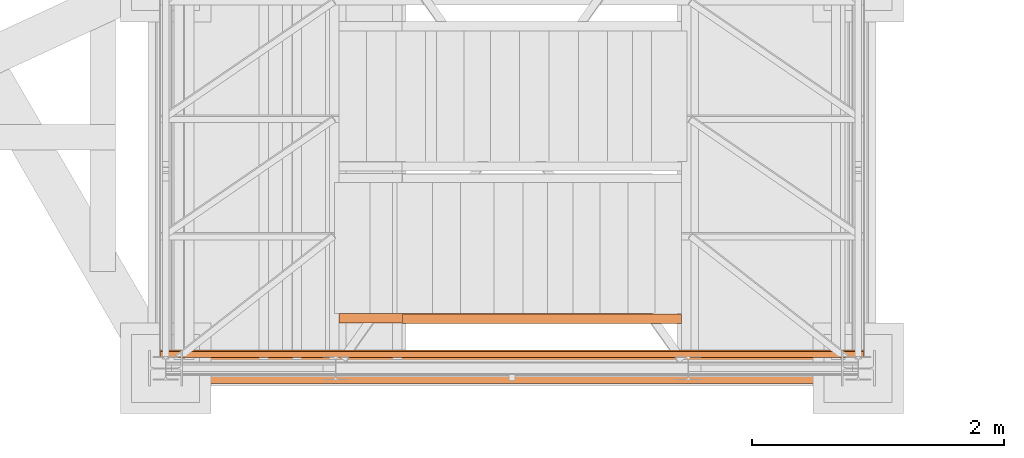
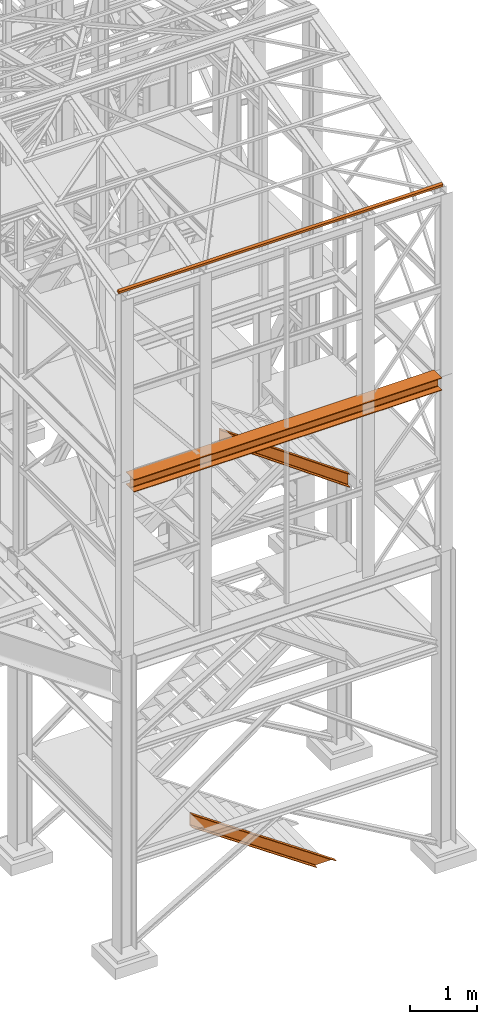
# One storey, part 42 of 208: 4 proxies.
"""IFC2X3 building model written with IfcOpenShell, lengths in millimetres."""

from ifc_helpers import new_model, entity, si_unit, converted_unit, frame, origin, origin_with_axes, place, context, subcontext, project, spatial, faceted_brep, element, save


model = new_model("IFC2X3")

# Units and contexts
model_context = context("Model", 3, precision=1e-05, world=origin())
plan_context = context("Plan", 3, precision=1e-05, world=origin())
body_context = subcontext(model_context, "Body", "Model", "MODEL_VIEW")
ifc_project = project(units=[si_unit("LENGTHUNIT", "METRE", prefix="MILLI"), converted_unit("PLANEANGLEUNIT", "DEGREE", entity("IfcPlaneAngleMeasure", 0.0174532925199433), si_unit("PLANEANGLEUNIT", "RADIAN"), dimensions=[0, 0, 0, 0, 0, 0, 0]), si_unit("AREAUNIT", "SQUARE_METRE"), si_unit("VOLUMEUNIT", "CUBIC_METRE")], contexts=[model_context, plan_context])

# Building, storey
building_placement = place(None, origin())
building = spatial("IfcBuilding", under=ifc_project, at=building_placement, CompositionType="COMPLEX")
storey_placement = place(building_placement, origin_with_axes())
storey = spatial("IfcBuildingStorey", under=building, at=storey_placement, Name="Geschoss", CompositionType="ELEMENT")

# Proxies
proxy_1_placement = place(storey_placement, frame((2573.108528797216, -24811.51916999359, -65.01000000000067), z_axis=(0.0, 0.0, 1.0), x_axis=(1.0, 0.0, 0.0)))
element("IfcBuildingElementProxy", 1, at=proxy_1_placement, inside=storey, context=body_context, shape_type="Brep", body=[
    faceted_brep([(0.01000000000112777, 75.01000111758549, 1472.287507638056), (2137.179805508645, 75.01000111758549, 0.01000000000048829), (2490.156434367033, 75.01000111758549, 0.01000000000040302), (0.01000000000112777, 75.01000111758549, 1715.010001055714), (0.01000000000112777, 75.01000111758549, 1715.010001055714), (2490.156434367033, 75.01000111758549, 0.01000000000040302), (2490.156434367033, 0.00999999999839929, 0.01000000000040302), (0.01000000000112777, 0.00999999999839929, 1715.010001055714), (0.01000000000112777, 0.00999999999839929, 1715.010001055714), (2490.156434367033, 0.00999999999839929, 0.01000000000040302), (2484.930913848925, 0.00999999999839929, 0.01000000000028933), (0.01000000000112777, 0.00999999999839929, 1711.416699783438), (0.01000000000112777, 0.00999999999839929, 1711.416699783438), (2484.930913848925, 0.00999999999839929, 0.01000000000028933), (2477.168952212082, 1.126000115869829, 0.0100000000003746), (0.01000000000112777, 1.126000115869829, 1706.079228324208), (0.01000000000112777, 1.126000115869829, 1706.079228324208), (2477.168952212082, 1.126000115869829, 0.0100000000003746), (2474.375335051584, 5.531528422830888, 0.01000000000071566), (0.01000000000021828, 5.531528422830888, 1704.158212405838), (0.01000000000021828, 5.531528422830888, 1704.158212405838), (2474.375335051584, 5.531528422830888, 0.01000000000071566), (2467.259955904038, 55.92706931590874, 0.01000000000054513), (0.01000000000112777, 55.92706931590874, 1699.265359941666), (0.01000000000112777, 55.92706931590874, 1699.265359941666), (2467.259955904038, 55.92706931590874, 0.01000000000054513), (2464.444576480061, 61.66620032697756, 0.01000000000080092), (0.01000000000112777, 61.66620032697756, 1697.329379319055), (0.01000000000112777, 61.66620032697756, 1697.329379319055), (2464.444576480061, 61.66620032697756, 0.01000000000080092), (2456.890349126264, 65.51985109060843, 0.01000000000034618), (0.01000000000203727, 65.51985109060843, 1692.134755229952), (0.01000000000203727, 65.51985109060843, 1692.134755229952), (2456.890349126264, 65.51985109060843, 0.01000000000034618), (2447.02844083364, 66.51000065564949, 0.01000000000034618), (0.01000000000112777, 66.51000065564949, 1685.353266669694), (0.01000000000112777, 66.51000065564949, 1685.353266669694), (2447.02844083364, 66.51000065564949, 0.01000000000034618), (2180.307799042043, 66.51000065564949, 0.01000000000031776), (0.01000000000112777, 66.51000065564949, 1501.944242024078), (0.01000000000112777, 66.51000065564949, 1501.944242024078), (2180.307799042043, 66.51000065564949, 0.01000000000031776), (2170.445890749416, 65.51985109060843, 0.01000000000026091), (0.01000000000112777, 65.51985109060843, 1495.162753463817), (0.01000000000112777, 65.51985109060843, 1495.162753463817), (2170.445890749416, 65.51985109060843, 0.01000000000026091), (2162.891663395619, 61.66620032697756, 0.01000000000031776), (0.01000000000112777, 61.66620032697756, 1489.968129374717), (0.01000000000112777, 61.66620032697756, 1489.968129374717), (2162.891663395619, 61.66620032697756, 0.01000000000031776), (2160.076283971642, 55.92706931590874, 0.01000000000071566), (0.01000000000112777, 55.92706931590874, 1488.032148752105), (0.01000000000112777, 55.92706931590874, 1488.032148752105), (2160.076283971642, 55.92706931590874, 0.01000000000071566), (2152.960904824097, 5.531528422830888, 0.01000000000003354), (0.01000000000112777, 5.531528422830888, 1483.139296287935), (0.01000000000112777, 5.531528422830888, 1483.139296287935), (2152.960904824097, 5.531528422830888, 0.01000000000003354), (2150.167287663598, 1.126000115869829, 0.01000000000003354), (0.01000000000112777, 1.126000115869829, 1481.218280369561), (0.01000000000112777, 1.126000115869829, 1481.218280369561), (2150.167287663598, 1.126000115869829, 0.01000000000003354), (2142.405326026755, 0.00999999999839929, 0.01000000000026091), (0.01000000000112777, 0.00999999999839929, 1475.880808910333), (0.01000000000112777, 0.00999999999839929, 1475.880808910333), (2142.405326026755, 0.00999999999839929, 0.01000000000026091), (2137.179805508647, 0.00999999999839929, 0.0100000000003746), (0.01000000000112777, 0.00999999999839929, 1472.287507638056), (0.01000000000112777, 0.00999999999839929, 1472.287507638056), (2137.179805508647, 0.00999999999839929, 0.0100000000003746), (2137.179805508645, 75.01000111758549, 0.01000000000048829), (0.01000000000112777, 75.01000111758549, 1472.287507638056), (0.01000000000112777, 75.01000111758549, 1715.010001055714), (0.01000000000112777, 0.00999999999839929, 1715.010001055714), (0.01000000000112777, 0.00999999999839929, 1711.416699783438), (0.01000000000112777, 1.126000115869829, 1706.079228324208), (0.01000000000021828, 5.531528422830888, 1704.158212405838), (0.01000000000112777, 55.92706931590874, 1699.265359941666), (0.01000000000112777, 61.66620032697756, 1697.329379319055), (0.01000000000203727, 65.51985109060843, 1692.134755229952), (0.01000000000112777, 66.51000065564949, 1685.353266669694), (0.01000000000112777, 66.51000065564949, 1501.944242024078), (0.01000000000112777, 65.51985109060843, 1495.162753463817), (0.01000000000112777, 61.66620032697756, 1489.968129374717), (0.01000000000112777, 55.92706931590874, 1488.032148752105), (0.01000000000112777, 5.531528422830888, 1483.139296287935), (0.01000000000112777, 1.126000115869829, 1481.218280369561), (0.01000000000112777, 0.00999999999839929, 1475.880808910333), (0.01000000000112777, 0.00999999999839929, 1472.287507638056), (0.01000000000112777, 75.01000111758549, 1472.287507638056), (2137.179805508645, 75.01000111758549, 0.01000000000048829), (2137.179805508647, 0.00999999999839929, 0.0100000000003746), (2142.405326026755, 0.00999999999839929, 0.01000000000026091), (2150.167287663598, 1.126000115869829, 0.01000000000003354), (2152.960904824097, 5.531528422830888, 0.01000000000003354), (2160.076283971642, 55.92706931590874, 0.01000000000071566), (2162.891663395619, 61.66620032697756, 0.01000000000031776), (2170.445890749416, 65.51985109060843, 0.01000000000026091), (2180.307799042043, 66.51000065564949, 0.01000000000031776), (2447.02844083364, 66.51000065564949, 0.01000000000034618), (2456.890349126264, 65.51985109060843, 0.01000000000034618), (2464.444576480061, 61.66620032697756, 0.01000000000080092), (2467.259955904038, 55.92706931590874, 0.01000000000054513), (2474.375335051584, 5.531528422830888, 0.01000000000071566), (2477.168952212082, 1.126000115869829, 0.0100000000003746), (2484.930913848925, 0.00999999999839929, 0.01000000000028933), (2490.156434367033, 0.00999999999839929, 0.01000000000040302), (2490.156434367033, 75.01000111758549, 0.01000000000040302)], [[[0, 1, 2, 3]], [[4, 5, 6, 7]], [[8, 9, 10, 11]], [[12, 13, 14, 15]], [[16, 17, 18, 19]], [[20, 21, 22, 23]], [[24, 25, 26, 27]], [[28, 29, 30, 31]], [[32, 33, 34, 35]], [[36, 37, 38, 39]], [[40, 41, 42, 43]], [[44, 45, 46, 47]], [[48, 49, 50, 51]], [[52, 53, 54, 55]], [[56, 57, 58, 59]], [[60, 61, 62, 63]], [[64, 65, 66, 67]], [[68, 69, 70, 71]], [[72, 73, 74, 75, 76, 77, 78, 79, 80, 81, 82, 83, 84, 85, 86, 87, 88, 89]], [[90, 91, 92, 93, 94, 95, 96, 97, 98, 99, 100, 101, 102, 103, 104, 105, 106, 107]]], orient=[[False], [False], [False], [False], [False], [False], [False], [False], [False], [False], [False], [False], [False], [False], [False], [False], [False], [False], [False], [False]]),
])
proxy_2_placement = place(storey_placement, frame((1298.207909539009, -25292.57439508626, 8254.989997913835), z_axis=(0.0, 0.0, 1.0), x_axis=(1.0, 0.0, 0.0)))
element("IfcBuildingElementProxy", 2, at=proxy_2_placement, inside=storey, context=body_context, shape_type="Brep", body=[
    faceted_brep([(0.01000000000203727, 0.00999999999839929, 0.01000000000021828), (5300.057057499541, 0.00999999999839929, 0.01000000000021828), (5300.057057499542, 240.0100095367416, 0.01000000000021828), (0.01000000000203727, 240.0100095367416, 0.01000000000021828), (0.01000000000203727, 240.0100095367416, 0.01000000000021828), (5300.057057499542, 240.0100095367416, 0.01000000000021828), (5300.057057499542, 240.0100095367416, 12.0100019669535), (0.01000000000203727, 240.0100095367416, 12.0100019669535), (0.01000000000203727, 240.0100095367416, 12.0100019669535), (5300.057057499542, 240.0100095367416, 12.0100019669535), (5300.057057499542, 144.7600064969047, 12.0100019669535), (0.01000000000203727, 144.7600064969047, 12.0100019669535), (0.01000000000203727, 144.7600064969047, 12.0100019669535), (5300.057057499542, 144.7600064969047, 12.0100019669535), (5300.057057499542, 133.8915605267866, 14.18530328035376), (0.01000000000203727, 133.8915605267866, 14.18530328035376), (0.01000000000203727, 133.8915605267866, 14.18530328035376), (5300.057057499542, 133.8915605267866, 14.18530328035376), (5300.057057499542, 125.9353108873947, 22.14155478239081), (0.01000000000203727, 125.9353108873947, 22.14155478239081), (0.01000000000203727, 125.9353108873947, 22.14155478239081), (5300.057057499542, 125.9353108873947, 22.14155478239081), (5300.057057499542, 123.7600049173816, 33.00999982118628), (0.01000000000112777, 123.7600049173816, 33.00999982118628), (0.01000000000112777, 123.7600049173816, 33.00999982118628), (5300.057057499542, 123.7600049173816, 33.00999982118628), (5300.057057499542, 123.7600049173816, 197.0100043511357), (0.01000000000203727, 123.7600049173816, 197.0100043511357), (0.01000000000203727, 123.7600049173816, 197.0100043511357), (5300.057057499542, 123.7600049173816, 197.0100043511357), (5300.057057499542, 125.9353108873947, 207.8784493899311), (0.01000000000294676, 125.9353108873947, 207.8784493899311), (0.01000000000294676, 125.9353108873947, 207.8784493899311), (5300.057057499542, 125.9353108873947, 207.8784493899311), (5300.057057499542, 133.8915605267866, 215.8347008919682), (0.01000000000385626, 133.8915605267866, 215.8347008919682), (0.01000000000385626, 133.8915605267866, 215.8347008919682), (5300.057057499542, 133.8915605267866, 215.8347008919682), (5300.057057499542, 144.7600064969047, 218.0100022053684), (0.01000000000203727, 144.7600064969047, 218.0100022053684), (0.01000000000203727, 144.7600064969047, 218.0100022053684), (5300.057057499542, 144.7600064969047, 218.0100022053684), (5300.057057499542, 240.0100095367416, 218.0100022053666), (0.01000000000203727, 240.0100095367416, 218.0100022053684), (0.01000000000203727, 240.0100095367416, 218.0100022053684), (5300.057057499542, 240.0100095367416, 218.0100022053666), (5300.057057499542, 240.0100095367416, 230.0100041723217), (0.01000000000203727, 240.0100095367416, 230.0100041723217), (0.01000000000203727, 240.0100095367416, 230.0100041723217), (5300.057057499542, 240.0100095367416, 230.0100041723217), (5300.057057499541, 0.00999999999839929, 230.0100041723217), (0.01000000000112777, 0.00999999999839929, 230.0100041723217), (0.01000000000112777, 0.00999999999839929, 230.0100041723217), (5300.057057499541, 0.00999999999839929, 230.0100041723217), (5300.057057499542, 0.00999999999839929, 218.0100022053684), (0.01000000000203727, 0.00999999999839929, 218.0100022053684), (0.01000000000203727, 0.00999999999839929, 218.0100022053684), (5300.057057499542, 0.00999999999839929, 218.0100022053684), (5300.057057499542, 95.26000303983528, 218.0100022053703), (0.01000000000203727, 95.26000303983528, 218.0100022053684), (0.01000000000203727, 95.26000303983528, 218.0100022053684), (5300.057057499542, 95.26000303983528, 218.0100022053703), (5300.057057499542, 106.1284490099533, 215.8347008919682), (0.01000000000294676, 106.1284490099533, 215.8347008919682), (0.01000000000294676, 106.1284490099533, 215.8347008919682), (5300.057057499542, 106.1284490099533, 215.8347008919682), (5300.057057499542, 114.0846986493452, 207.8784493899311), (0.01000000000021828, 114.0846986493452, 207.8784493899311), (0.01000000000021828, 114.0846986493452, 207.8784493899311), (5300.057057499542, 114.0846986493452, 207.8784493899311), (5300.057057499542, 116.2600046193584, 197.0100043511357), (0.01000000000294676, 116.2600046193584, 197.0100043511357), (0.01000000000294676, 116.2600046193584, 197.0100043511357), (5300.057057499542, 116.2600046193584, 197.0100043511357), (5300.057057499542, 116.2600046193584, 33.00999982118628), (0.01000000000112777, 116.2600046193584, 33.00999982118628), (0.01000000000112777, 116.2600046193584, 33.00999982118628), (5300.057057499542, 116.2600046193584, 33.00999982118628), (5300.057057499542, 114.0846986493452, 22.14155478239081), (0.01000000000203727, 114.0846986493452, 22.14155478239081), (0.01000000000203727, 114.0846986493452, 22.14155478239081), (5300.057057499542, 114.0846986493452, 22.14155478239081), (5300.057057499542, 106.1284490099533, 14.18530328035376), (0.01000000000112777, 106.1284490099533, 14.18530328035376), (0.01000000000112777, 106.1284490099533, 14.18530328035376), (5300.057057499542, 106.1284490099533, 14.18530328035376), (5300.057057499542, 95.26000303983528, 12.0100019669535), (0.01000000000294676, 95.26000303983528, 12.0100019669535), (0.01000000000294676, 95.26000303983528, 12.0100019669535), (5300.057057499542, 95.26000303983528, 12.0100019669535), (5300.057057499541, 0.00999999999839929, 12.0100019669535), (0.01000000000203727, 0.00999999999839929, 12.0100019669535), (0.01000000000203727, 0.00999999999839929, 12.0100019669535), (5300.057057499541, 0.00999999999839929, 12.0100019669535), (5300.057057499541, 0.00999999999839929, 0.01000000000021828), (0.01000000000203727, 0.00999999999839929, 0.01000000000021828), (5300.057057499542, 240.0100095367416, 0.01000000000021828), (5300.057057499541, 0.00999999999839929, 0.01000000000021828), (5300.057057499541, 0.00999999999839929, 12.0100019669535), (5300.057057499542, 95.26000303983528, 12.0100019669535), (5300.057057499542, 106.1284490099533, 14.18530328035376), (5300.057057499542, 114.0846986493452, 22.14155478239081), (5300.057057499542, 116.2600046193584, 33.00999982118628), (5300.057057499542, 116.2600046193584, 197.0100043511357), (5300.057057499542, 114.0846986493452, 207.8784493899311), (5300.057057499542, 106.1284490099533, 215.8347008919682), (5300.057057499542, 95.26000303983528, 218.0100022053703), (5300.057057499542, 0.00999999999839929, 218.0100022053684), (5300.057057499541, 0.00999999999839929, 230.0100041723217), (5300.057057499542, 240.0100095367416, 230.0100041723217), (5300.057057499542, 240.0100095367416, 218.0100022053666), (5300.057057499542, 144.7600064969047, 218.0100022053684), (5300.057057499542, 133.8915605267866, 215.8347008919682), (5300.057057499542, 125.9353108873947, 207.8784493899311), (5300.057057499542, 123.7600049173816, 197.0100043511357), (5300.057057499542, 123.7600049173816, 33.00999982118628), (5300.057057499542, 125.9353108873947, 22.14155478239081), (5300.057057499542, 133.8915605267866, 14.18530328035376), (5300.057057499542, 144.7600064969047, 12.0100019669535), (5300.057057499542, 240.0100095367416, 12.0100019669535), (0.01000000000203727, 0.00999999999839929, 0.01000000000021828), (0.01000000000203727, 240.0100095367416, 0.01000000000021828), (0.01000000000203727, 240.0100095367416, 12.0100019669535), (0.01000000000203727, 144.7600064969047, 12.0100019669535), (0.01000000000203727, 133.8915605267866, 14.18530328035376), (0.01000000000203727, 125.9353108873947, 22.14155478239081), (0.01000000000112777, 123.7600049173816, 33.00999982118628), (0.01000000000203727, 123.7600049173816, 197.0100043511357), (0.01000000000294676, 125.9353108873947, 207.8784493899311), (0.01000000000385626, 133.8915605267866, 215.8347008919682), (0.01000000000203727, 144.7600064969047, 218.0100022053684), (0.01000000000203727, 240.0100095367416, 218.0100022053684), (0.01000000000203727, 240.0100095367416, 230.0100041723217), (0.01000000000112777, 0.00999999999839929, 230.0100041723217), (0.01000000000203727, 0.00999999999839929, 218.0100022053684), (0.01000000000203727, 95.26000303983528, 218.0100022053684), (0.01000000000294676, 106.1284490099533, 215.8347008919682), (0.01000000000021828, 114.0846986493452, 207.8784493899311), (0.01000000000294676, 116.2600046193584, 197.0100043511357), (0.01000000000112777, 116.2600046193584, 33.00999982118628), (0.01000000000203727, 114.0846986493452, 22.14155478239081), (0.01000000000112777, 106.1284490099533, 14.18530328035376), (0.01000000000294676, 95.26000303983528, 12.0100019669535), (0.01000000000203727, 0.00999999999839929, 12.0100019669535)], [[[0, 1, 2, 3]], [[4, 5, 6, 7]], [[8, 9, 10, 11]], [[12, 13, 14, 15]], [[16, 17, 18, 19]], [[20, 21, 22, 23]], [[24, 25, 26, 27]], [[28, 29, 30, 31]], [[32, 33, 34, 35]], [[36, 37, 38, 39]], [[40, 41, 42, 43]], [[44, 45, 46, 47]], [[48, 49, 50, 51]], [[52, 53, 54, 55]], [[56, 57, 58, 59]], [[60, 61, 62, 63]], [[64, 65, 66, 67]], [[68, 69, 70, 71]], [[72, 73, 74, 75]], [[76, 77, 78, 79]], [[80, 81, 82, 83]], [[84, 85, 86, 87]], [[88, 89, 90, 91]], [[92, 93, 94, 95]], [[96, 97, 98, 99, 100, 101, 102, 103, 104, 105, 106, 107, 108, 109, 110, 111, 112, 113, 114, 115, 116, 117, 118, 119]], [[120, 121, 122, 123, 124, 125, 126, 127, 128, 129, 130, 131, 132, 133, 134, 135, 136, 137, 138, 139, 140, 141, 142, 143]]], orient=[[False], [False], [False], [False], [False], [False], [False], [False], [False], [False], [False], [False], [False], [False], [False], [False], [False], [False], [False], [False], [False], [False], [False], [False], [False], [False]]),
])
proxy_3_placement = place(storey_placement, frame((3076.75804237704, -24817.42795058643, 6651.257815805529), z_axis=(0.0, 0.0, 1.0), x_axis=(1.0, 0.0, 0.0)))
element("IfcBuildingElementProxy", 3, at=proxy_3_placement, inside=storey, context=body_context, shape_type="Brep", body=[
    faceted_brep([(0.01000000000112777, 75.01000111758549, 1824.742182942768), (0.01000000000112777, 75.01000111758549, 1579.178796878196), (2216.653365883076, 75.01000111758549, 0.01000000000021828), (2216.653365883077, 75.01000111758549, 245.5733860645723), (0.01000000000112777, 0.00999999999839929, 1824.742182942768), (0.01000000000112777, 75.01000111758549, 1824.742182942768), (2216.653365883077, 75.01000111758549, 245.5733860645723), (2216.653365883077, 0.00999999999839929, 245.5733860645723), (0.01000000000021828, 0.00999999999839929, 1821.106824657076), (0.01000000000112777, 0.00999999999839929, 1824.742182942768), (2216.653365883077, 0.00999999999839929, 245.5733860645723), (2216.653365883077, 0.00999999999839929, 241.9380277788796), (0.01000000000203727, 1.126000115869829, 1815.706881923723), (0.01000000000021828, 0.00999999999839929, 1821.106824657076), (2216.653365883077, 0.00999999999839929, 241.9380277788796), (2216.653365883077, 1.126000115869829, 236.5380850455276), (0.01000000000203727, 5.531528422830888, 1813.763381892237), (0.01000000000203727, 1.126000115869829, 1815.706881923723), (2216.653365883077, 1.126000115869829, 236.5380850455276), (2216.653365883076, 5.531528422830888, 234.5945850140433), (0.01000000000203727, 55.92706931590874, 1808.813262100295), (0.01000000000203727, 5.531528422830888, 1813.763381892237), (2216.653365883076, 5.531528422830888, 234.5945850140433), (2216.653365883077, 55.92706931590874, 229.6444652221016), (0.01000000000112777, 61.66620032697756, 1806.854622213445), (0.01000000000203727, 55.92706931590874, 1808.813262100295), (2216.653365883077, 55.92706931590874, 229.6444652221016), (2216.653365883077, 61.66620032697756, 227.6858253352502), (0.01000000000112777, 65.51985109060843, 1801.599198776206), (0.01000000000112777, 61.66620032697756, 1806.854622213445), (2216.653365883077, 61.66620032697756, 227.6858253352502), (2216.653365883077, 65.51985109060843, 222.4304018980101), (0.01000000000112777, 66.51000065564949, 1794.738337757652), (0.01000000000112777, 65.51985109060843, 1801.599198776206), (2216.653365883077, 65.51985109060843, 222.4304018980101), (2216.653365883078, 66.51000065564949, 215.5695408794563), (0.01000000000112777, 66.51000065564949, 1609.182642063313), (0.01000000000112777, 66.51000065564949, 1794.738337757652), (2216.653365883078, 66.51000065564949, 215.5695408794563), (2216.653365883077, 66.51000065564949, 30.01384518511804), (0.01000000000021828, 65.51985109060843, 1602.321781044757), (0.01000000000112777, 66.51000065564949, 1609.182642063313), (2216.653365883077, 66.51000065564949, 30.01384518511804), (2216.653365883077, 65.51985109060843, 23.15298416656151), (0.01000000000112777, 61.66620032697756, 1597.066357607517), (0.01000000000021828, 65.51985109060843, 1602.321781044757), (2216.653365883077, 65.51985109060843, 23.15298416656151), (2216.653365883077, 61.66620032697756, 17.89756072932141), (0.01000000000203727, 55.92706931590874, 1595.107717720666), (0.01000000000112777, 61.66620032697756, 1597.066357607517), (2216.653365883077, 61.66620032697756, 17.89756072932141), (2216.653365883077, 55.92706931590874, 15.93892084247273), (0.01000000000112777, 5.531528422830888, 1590.157597928728), (0.01000000000203727, 55.92706931590874, 1595.107717720666), (2216.653365883077, 55.92706931590874, 15.93892084247273), (2216.653365883077, 5.531528422830888, 10.98880105053104), (0.01000000000112777, 1.126000115869829, 1588.21409789724), (0.01000000000112777, 5.531528422830888, 1590.157597928728), (2216.653365883077, 5.531528422830888, 10.98880105053104), (2216.653365883077, 1.126000115869829, 9.045301019044928), (0.01000000000021828, 0.00999999999839929, 1582.814155163889), (0.01000000000112777, 1.126000115869829, 1588.21409789724), (2216.653365883077, 1.126000115869829, 9.045301019044928), (2216.653365883077, 0.00999999999839929, 3.645358285693874), (0.01000000000021828, 0.00999999999839929, 1579.178796878196), (0.01000000000021828, 0.00999999999839929, 1582.814155163889), (2216.653365883077, 0.00999999999839929, 3.645358285693874), (2216.653365883077, 0.00999999999839929, 0.01000000000021828), (0.01000000000112777, 75.01000111758549, 1579.178796878196), (0.01000000000021828, 0.00999999999839929, 1579.178796878196), (2216.653365883077, 0.00999999999839929, 0.01000000000021828), (2216.653365883076, 75.01000111758549, 0.01000000000021828), (2216.653365883076, 75.01000111758549, 0.01000000000021828), (2216.653365883077, 0.00999999999839929, 0.01000000000021828), (2216.653365883077, 0.00999999999839929, 3.645358285693874), (2216.653365883077, 1.126000115869829, 9.045301019044928), (2216.653365883077, 5.531528422830888, 10.98880105053104), (2216.653365883077, 55.92706931590874, 15.93892084247273), (2216.653365883077, 61.66620032697756, 17.89756072932141), (2216.653365883077, 65.51985109060843, 23.15298416656151), (2216.653365883077, 66.51000065564949, 30.01384518511804), (2216.653365883078, 66.51000065564949, 215.5695408794563), (2216.653365883077, 65.51985109060843, 222.4304018980101), (2216.653365883077, 61.66620032697756, 227.6858253352502), (2216.653365883077, 55.92706931590874, 229.6444652221016), (2216.653365883076, 5.531528422830888, 234.5945850140433), (2216.653365883077, 1.126000115869829, 236.5380850455276), (2216.653365883077, 0.00999999999839929, 241.9380277788796), (2216.653365883077, 0.00999999999839929, 245.5733860645723), (2216.653365883077, 75.01000111758549, 245.5733860645723), (0.01000000000112777, 75.01000111758549, 1824.742182942768), (0.01000000000112777, 0.00999999999839929, 1824.742182942768), (0.01000000000021828, 0.00999999999839929, 1821.106824657076), (0.01000000000203727, 1.126000115869829, 1815.706881923723), (0.01000000000203727, 5.531528422830888, 1813.763381892237), (0.01000000000203727, 55.92706931590874, 1808.813262100295), (0.01000000000112777, 61.66620032697756, 1806.854622213445), (0.01000000000112777, 65.51985109060843, 1801.599198776206), (0.01000000000112777, 66.51000065564949, 1794.738337757652), (0.01000000000112777, 66.51000065564949, 1609.182642063313), (0.01000000000021828, 65.51985109060843, 1602.321781044757), (0.01000000000112777, 61.66620032697756, 1597.066357607517), (0.01000000000203727, 55.92706931590874, 1595.107717720666), (0.01000000000112777, 5.531528422830888, 1590.157597928728), (0.01000000000112777, 1.126000115869829, 1588.21409789724), (0.01000000000021828, 0.00999999999839929, 1582.814155163889), (0.01000000000021828, 0.00999999999839929, 1579.178796878196), (0.01000000000112777, 75.01000111758549, 1579.178796878196)], [[[0, 1, 2, 3]], [[4, 5, 6, 7]], [[8, 9, 10, 11]], [[12, 13, 14, 15]], [[16, 17, 18, 19]], [[20, 21, 22, 23]], [[24, 25, 26, 27]], [[28, 29, 30, 31]], [[32, 33, 34, 35]], [[36, 37, 38, 39]], [[40, 41, 42, 43]], [[44, 45, 46, 47]], [[48, 49, 50, 51]], [[52, 53, 54, 55]], [[56, 57, 58, 59]], [[60, 61, 62, 63]], [[64, 65, 66, 67]], [[68, 69, 70, 71]], [[72, 73, 74, 75, 76, 77, 78, 79, 80, 81, 82, 83, 84, 85, 86, 87, 88, 89]], [[90, 91, 92, 93, 94, 95, 96, 97, 98, 99, 100, 101, 102, 103, 104, 105, 106, 107]]], orient=[[False], [False], [False], [False], [False], [False], [False], [False], [False], [False], [False], [False], [False], [False], [False], [False], [False], [False], [False], [False]]),
])
proxy_4_placement = place(storey_placement, frame((1157.254971121462, -25087.70244538405, 11785.77681726853), z_axis=(0.0, 0.0, 1.0), x_axis=(1.0, 0.0, 0.0)))
element("IfcBuildingElementProxy", 4, at=proxy_4_placement, inside=storey, context=body_context, shape_type="Brep", body=[
    faceted_brep([(5582.010002264974, 48.59909357395736, 60.39315927079588), (5582.010002264974, 60.39315927079224, 11.80406569683873), (5582.010002264974, 11.80406569683692, 0.01000000000021828), (5582.010002264974, 0.00999999999839929, 48.59909357395736), (0.01000000000021828, 0.00999999999839929, 48.59909357395736), (0.01000000000021828, 11.80406569683692, 0.01000000000021828), (0.01000000000021828, 60.39315927079588, 11.80406569683873), (0.01000000000021828, 48.59909357395736, 60.39315927079588), (5582.010002264974, 0.00999999999839929, 48.59909357395736), (0.01000000000021828, 0.00999999999839929, 48.59909357395736), (0.01000000000021828, 48.59909357395736, 60.39315927079588), (5582.010002264974, 48.59909357395736, 60.39315927079588), (5582.010002264974, 11.80406569683692, 0.01000000000021828), (0.01000000000021828, 11.80406569683692, 0.01000000000021828), (0.01000000000021828, 0.00999999999839929, 48.59909357395736), (5582.010002264974, 0.00999999999839929, 48.59909357395736), (5582.010002264974, 60.39315927079224, 11.80406569683873), (0.01000000000021828, 60.39315927079588, 11.80406569683873), (0.01000000000021828, 11.80406569683692, 0.01000000000021828), (5582.010002264974, 11.80406569683692, 0.01000000000021828), (5582.010002264974, 48.59909357395736, 60.39315927079588), (0.01000000000021828, 48.59909357395736, 60.39315927079588), (0.01000000000021828, 60.39315927079588, 11.80406569683873), (5582.010002264974, 60.39315927079224, 11.80406569683873)], [[[0, 1, 2, 3]], [[4, 5, 6, 7]], [[8, 9, 10, 11]], [[12, 13, 14, 15]], [[16, 17, 18, 19]], [[20, 21, 22, 23]]], orient=[[False], [False], [False], [False], [False], [False]]),
])

save(model, "model.ifc")
